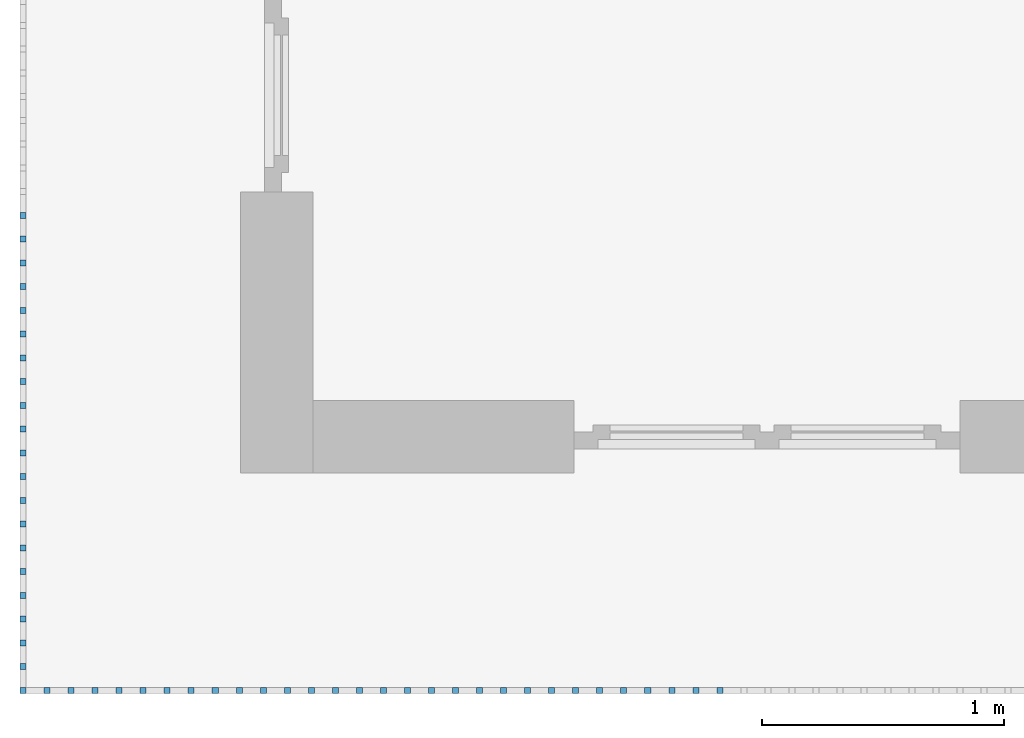
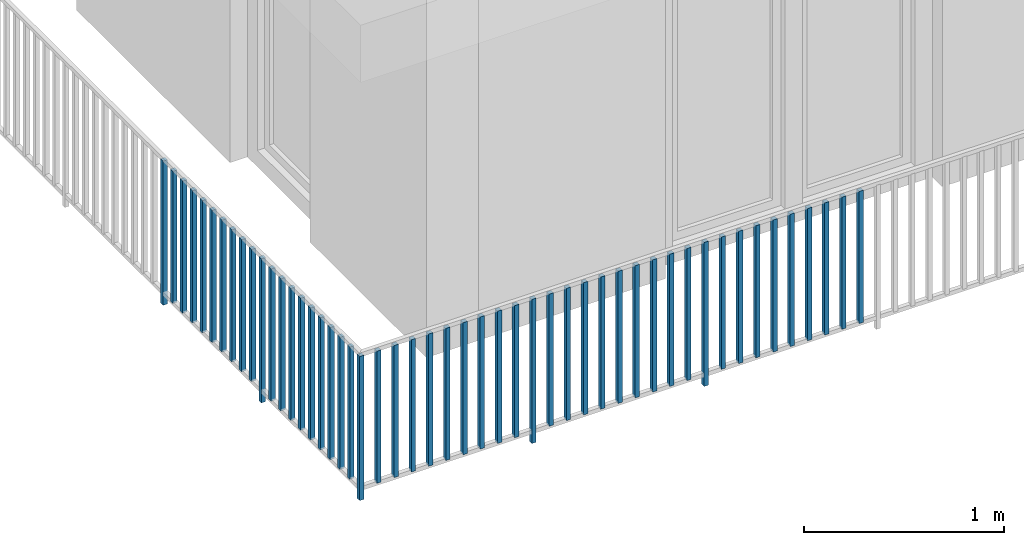
# One storey, part 25 of 48: 50 building element parts, 1 element without a shape of its own.
"""IFC4 building model written with IfcOpenShell, lengths in metres."""

from ifc_helpers import new_model, entity, si_unit, converted_unit, derived_unit, direction, frame, origin_with_axes, place, context, subcontext, project, spatial, polygons, material, type_object, element, aggregate, save


model = new_model("IFC4")

# Units and contexts
model_context = context("Model", 3, precision=1e-05, world=origin_with_axes(), true_north=direction((0.0, 1.0)))
body_context = subcontext(model_context, "Body", "Model", "MODEL_VIEW")
ifc_project = project(units=[si_unit("LENGTHUNIT", "METRE"), si_unit("AREAUNIT", "SQUARE_METRE"), si_unit("VOLUMEUNIT", "CUBIC_METRE"), converted_unit("PLANEANGLEUNIT", "DEGREE", entity("IfcPlaneAngleMeasure", 0.0174532925199), si_unit("PLANEANGLEUNIT", "RADIAN"), dimensions=[0, 0, 0, 0, 0, 0, 0]), converted_unit("TIMEUNIT", "Year", entity("IfcTimeMeasure", 31556926.0), si_unit("TIMEUNIT", "SECOND"), dimensions=[0, 0, 1, 0, 0, 0, 0]), si_unit("MASSUNIT", "GRAM", prefix="KILO"), si_unit("THERMODYNAMICTEMPERATUREUNIT", "DEGREE_CELSIUS"), si_unit("LUMINOUSINTENSITYUNIT", "LUMEN"), si_unit("ENERGYUNIT", "JOULE", prefix="MEGA"), derived_unit("THERMALCONDUCTANCEUNIT", [(si_unit("POWERUNIT", "WATT"), 1), (si_unit("LENGTHUNIT", "METRE"), -1), (si_unit("THERMODYNAMICTEMPERATUREUNIT", "KELVIN"), -1)]), derived_unit("SPECIFICHEATCAPACITYUNIT", [(si_unit("ENERGYUNIT", "JOULE"), 1), (si_unit("MASSUNIT", "GRAM", prefix="KILO"), -1), (si_unit("THERMODYNAMICTEMPERATUREUNIT", "KELVIN"), -1)]), derived_unit("MASSDENSITYUNIT", [(si_unit("MASSUNIT", "GRAM", prefix="KILO"), 1), (si_unit("VOLUMEUNIT", "CUBIC_METRE"), -1)])], contexts=[model_context])

# Site, building, storey
site_placement = place(None, origin_with_axes())
site = spatial("IfcSite", under=ifc_project, at=site_placement, CompositionType="ELEMENT")
building_placement = place(site_placement, origin_with_axes())
building = spatial("IfcBuilding", under=site, at=building_placement, CompositionType="ELEMENT")
storey_placement = place(building_placement, frame((0.0, 0.0, 3.4), z_axis=(0.0, 0.0, 1.0), x_axis=(1.0, 0.0, 0.0)))
storey = spatial("IfcBuildingStorey", under=building, at=storey_placement, Name="1. Geschoss", CompositionType="ELEMENT", Elevation=3.4)

# Railing, building element parts
railing_type = type_object("IfcRailingType", PredefinedType="NOTDEFINED")
railing_placement = place(storey_placement, frame((10.2378006196, 9.82118776896, 0.0), z_axis=(0.0, 0.0, 1.0), x_axis=(1.0, 0.0, 0.0)))
railing = element("IfcRailing", 1, at=railing_placement, inside=storey, type_object=railing_type, PredefinedType="NOTDEFINED")
ifc_material = material()
building_element_part_1_placement = place(railing_placement, origin_with_axes())
building_element_part_1 = element("IfcBuildingElementPart", 2, at=building_element_part_1_placement, material=ifc_material, PredefinedType="NOTDEFINED", context=body_context, shape_type="Tessellation", body=[
    polygons([(-22.8925, -20.6625, 0.0), (-22.8675, -20.6625, 0.0), (-22.8675, -20.6625, 0.88), (-22.8925, -20.6625, 0.88), (-22.8925, -20.6375, 0.0), (-22.8675, -20.6375, 0.0), (-22.8675, -20.6375, 0.88), (-22.8925, -20.6375, 0.88)], [[[1, 2, 3, 4]], [[1, 5, 6, 2]], [[2, 6, 7, 3]], [[4, 3, 7, 8]], [[5, 1, 4, 8]], [[6, 5, 8, 7]]], closed=True),
])
building_element_part_2_placement = place(railing_placement, origin_with_axes())
building_element_part_2 = element("IfcBuildingElementPart", 3, at=building_element_part_2_placement, material=ifc_material, PredefinedType="NOTDEFINED", context=body_context, shape_type="Tessellation", body=[
    polygons([(-22.8925, -18.6958333333, 0.0), (-22.8675, -18.6958333333, 0.0), (-22.8675, -18.6958333333, 0.88), (-22.8925, -18.6958333333, 0.88), (-22.8925, -18.6708333333, 0.0), (-22.8675, -18.6708333333, 0.0), (-22.8675, -18.6708333333, 0.88), (-22.8925, -18.6708333333, 0.88)], [[[1, 2, 3, 4]], [[1, 5, 6, 2]], [[2, 6, 7, 3]], [[4, 3, 7, 8]], [[5, 1, 4, 8]], [[6, 5, 8, 7]]], closed=True),
])
building_element_part_3_placement = place(railing_placement, origin_with_axes())
building_element_part_3 = element("IfcBuildingElementPart", 4, at=building_element_part_3_placement, material=ifc_material, PredefinedType="NOTDEFINED", context=body_context, shape_type="Tessellation", body=[
    polygons([(-22.8925, -18.7941666667, 0.07), (-22.8675, -18.7941666667, 0.07), (-22.8675, -18.7941666667, 0.8775), (-22.8925, -18.7941666667, 0.8775), (-22.8925, -18.7691666667, 0.07), (-22.8675, -18.7691666667, 0.07), (-22.8675, -18.7691666667, 0.8775), (-22.8925, -18.7691666667, 0.8775)], [[[1, 2, 3, 4]], [[1, 5, 6, 2]], [[2, 6, 7, 3]], [[4, 3, 7, 8]], [[5, 1, 4, 8]], [[6, 5, 8, 7]]], closed=True),
])
building_element_part_4_placement = place(railing_placement, origin_with_axes())
building_element_part_4 = element("IfcBuildingElementPart", 5, at=building_element_part_4_placement, material=ifc_material, PredefinedType="NOTDEFINED", context=body_context, shape_type="Tessellation", body=[
    polygons([(-22.8925, -18.8925, 0.07), (-22.8675, -18.8925, 0.07), (-22.8675, -18.8925, 0.8775), (-22.8925, -18.8925, 0.8775), (-22.8925, -18.8675, 0.07), (-22.8675, -18.8675, 0.07), (-22.8675, -18.8675, 0.8775), (-22.8925, -18.8675, 0.8775)], [[[1, 2, 3, 4]], [[1, 5, 6, 2]], [[2, 6, 7, 3]], [[4, 3, 7, 8]], [[5, 1, 4, 8]], [[6, 5, 8, 7]]], closed=True),
])
building_element_part_5_placement = place(railing_placement, origin_with_axes())
building_element_part_5 = element("IfcBuildingElementPart", 6, at=building_element_part_5_placement, material=ifc_material, PredefinedType="NOTDEFINED", context=body_context, shape_type="Tessellation", body=[
    polygons([(-22.8925, -18.9908333333, 0.07), (-22.8675, -18.9908333333, 0.07), (-22.8675, -18.9908333333, 0.8775), (-22.8925, -18.9908333333, 0.8775), (-22.8925, -18.9658333333, 0.07), (-22.8675, -18.9658333333, 0.07), (-22.8675, -18.9658333333, 0.8775), (-22.8925, -18.9658333333, 0.8775)], [[[1, 2, 3, 4]], [[1, 5, 6, 2]], [[2, 6, 7, 3]], [[4, 3, 7, 8]], [[5, 1, 4, 8]], [[6, 5, 8, 7]]], closed=True),
])
building_element_part_6_placement = place(railing_placement, origin_with_axes())
building_element_part_6 = element("IfcBuildingElementPart", 7, at=building_element_part_6_placement, material=ifc_material, PredefinedType="NOTDEFINED", context=body_context, shape_type="Tessellation", body=[
    polygons([(-22.8925, -19.0891666667, 0.07), (-22.8675, -19.0891666667, 0.07), (-22.8675, -19.0891666667, 0.8775), (-22.8925, -19.0891666667, 0.8775), (-22.8925, -19.0641666667, 0.07), (-22.8675, -19.0641666667, 0.07), (-22.8675, -19.0641666667, 0.8775), (-22.8925, -19.0641666667, 0.8775)], [[[1, 2, 3, 4]], [[1, 5, 6, 2]], [[2, 6, 7, 3]], [[4, 3, 7, 8]], [[5, 1, 4, 8]], [[6, 5, 8, 7]]], closed=True),
])
building_element_part_7_placement = place(railing_placement, origin_with_axes())
building_element_part_7 = element("IfcBuildingElementPart", 8, at=building_element_part_7_placement, material=ifc_material, PredefinedType="NOTDEFINED", context=body_context, shape_type="Tessellation", body=[
    polygons([(-22.8925, -19.1875, 0.07), (-22.8675, -19.1875, 0.07), (-22.8675, -19.1875, 0.8775), (-22.8925, -19.1875, 0.8775), (-22.8925, -19.1625, 0.07), (-22.8675, -19.1625, 0.07), (-22.8675, -19.1625, 0.8775), (-22.8925, -19.1625, 0.8775)], [[[1, 2, 3, 4]], [[1, 5, 6, 2]], [[2, 6, 7, 3]], [[4, 3, 7, 8]], [[5, 1, 4, 8]], [[6, 5, 8, 7]]], closed=True),
])
building_element_part_8_placement = place(railing_placement, origin_with_axes())
building_element_part_8 = element("IfcBuildingElementPart", 9, at=building_element_part_8_placement, material=ifc_material, PredefinedType="NOTDEFINED", context=body_context, shape_type="Tessellation", body=[
    polygons([(-22.8925, -19.2858333333, 0.07), (-22.8675, -19.2858333333, 0.07), (-22.8675, -19.2858333333, 0.8775), (-22.8925, -19.2858333333, 0.8775), (-22.8925, -19.2608333333, 0.07), (-22.8675, -19.2608333333, 0.07), (-22.8675, -19.2608333333, 0.8775), (-22.8925, -19.2608333333, 0.8775)], [[[1, 2, 3, 4]], [[1, 5, 6, 2]], [[2, 6, 7, 3]], [[4, 3, 7, 8]], [[5, 1, 4, 8]], [[6, 5, 8, 7]]], closed=True),
])
building_element_part_9_placement = place(railing_placement, origin_with_axes())
building_element_part_9 = element("IfcBuildingElementPart", 10, at=building_element_part_9_placement, material=ifc_material, PredefinedType="NOTDEFINED", context=body_context, shape_type="Tessellation", body=[
    polygons([(-22.8925, -19.3841666667, 0.07), (-22.8675, -19.3841666667, 0.07), (-22.8675, -19.3841666667, 0.8775), (-22.8925, -19.3841666667, 0.8775), (-22.8925, -19.3591666667, 0.07), (-22.8675, -19.3591666667, 0.07), (-22.8675, -19.3591666667, 0.8775), (-22.8925, -19.3591666667, 0.8775)], [[[1, 2, 3, 4]], [[1, 5, 6, 2]], [[2, 6, 7, 3]], [[4, 3, 7, 8]], [[5, 1, 4, 8]], [[6, 5, 8, 7]]], closed=True),
])
building_element_part_10_placement = place(railing_placement, origin_with_axes())
building_element_part_10 = element("IfcBuildingElementPart", 11, at=building_element_part_10_placement, material=ifc_material, PredefinedType="NOTDEFINED", context=body_context, shape_type="Tessellation", body=[
    polygons([(-22.8925, -19.4825, 0.07), (-22.8675, -19.4825, 0.07), (-22.8675, -19.4825, 0.8775), (-22.8925, -19.4825, 0.8775), (-22.8925, -19.4575, 0.07), (-22.8675, -19.4575, 0.07), (-22.8675, -19.4575, 0.8775), (-22.8925, -19.4575, 0.8775)], [[[1, 2, 3, 4]], [[1, 5, 6, 2]], [[2, 6, 7, 3]], [[4, 3, 7, 8]], [[5, 1, 4, 8]], [[6, 5, 8, 7]]], closed=True),
])
building_element_part_11_placement = place(railing_placement, origin_with_axes())
building_element_part_11 = element("IfcBuildingElementPart", 12, at=building_element_part_11_placement, material=ifc_material, PredefinedType="NOTDEFINED", context=body_context, shape_type="Tessellation", body=[
    polygons([(-22.8925, -19.5808333333, 0.07), (-22.8675, -19.5808333333, 0.07), (-22.8675, -19.5808333333, 0.8775), (-22.8925, -19.5808333333, 0.8775), (-22.8925, -19.5558333333, 0.07), (-22.8675, -19.5558333333, 0.07), (-22.8675, -19.5558333333, 0.8775), (-22.8925, -19.5558333333, 0.8775)], [[[1, 2, 3, 4]], [[1, 5, 6, 2]], [[2, 6, 7, 3]], [[4, 3, 7, 8]], [[5, 1, 4, 8]], [[6, 5, 8, 7]]], closed=True),
])
building_element_part_12_placement = place(railing_placement, origin_with_axes())
building_element_part_12 = element("IfcBuildingElementPart", 13, at=building_element_part_12_placement, material=ifc_material, PredefinedType="NOTDEFINED", context=body_context, shape_type="Tessellation", body=[
    polygons([(-22.8925, -19.6791666667, 0.0), (-22.8675, -19.6791666667, 0.0), (-22.8675, -19.6791666667, 0.88), (-22.8925, -19.6791666667, 0.88), (-22.8925, -19.6541666667, 0.0), (-22.8675, -19.6541666667, 0.0), (-22.8675, -19.6541666667, 0.88), (-22.8925, -19.6541666667, 0.88)], [[[1, 2, 3, 4]], [[1, 5, 6, 2]], [[2, 6, 7, 3]], [[4, 3, 7, 8]], [[5, 1, 4, 8]], [[6, 5, 8, 7]]], closed=True),
])
building_element_part_13_placement = place(railing_placement, origin_with_axes())
building_element_part_13 = element("IfcBuildingElementPart", 14, at=building_element_part_13_placement, material=ifc_material, PredefinedType="NOTDEFINED", context=body_context, shape_type="Tessellation", body=[
    polygons([(-22.8925, -19.7775, 0.07), (-22.8675, -19.7775, 0.07), (-22.8675, -19.7775, 0.8775), (-22.8925, -19.7775, 0.8775), (-22.8925, -19.7525, 0.07), (-22.8675, -19.7525, 0.07), (-22.8675, -19.7525, 0.8775), (-22.8925, -19.7525, 0.8775)], [[[1, 2, 3, 4]], [[1, 5, 6, 2]], [[2, 6, 7, 3]], [[4, 3, 7, 8]], [[5, 1, 4, 8]], [[6, 5, 8, 7]]], closed=True),
])
building_element_part_14_placement = place(railing_placement, origin_with_axes())
building_element_part_14 = element("IfcBuildingElementPart", 15, at=building_element_part_14_placement, material=ifc_material, PredefinedType="NOTDEFINED", context=body_context, shape_type="Tessellation", body=[
    polygons([(-22.8925, -19.8758333333, 0.07), (-22.8675, -19.8758333333, 0.07), (-22.8675, -19.8758333333, 0.8775), (-22.8925, -19.8758333333, 0.8775), (-22.8925, -19.8508333333, 0.07), (-22.8675, -19.8508333333, 0.07), (-22.8675, -19.8508333333, 0.8775), (-22.8925, -19.8508333333, 0.8775)], [[[1, 2, 3, 4]], [[1, 5, 6, 2]], [[2, 6, 7, 3]], [[4, 3, 7, 8]], [[5, 1, 4, 8]], [[6, 5, 8, 7]]], closed=True),
])
building_element_part_15_placement = place(railing_placement, origin_with_axes())
building_element_part_15 = element("IfcBuildingElementPart", 16, at=building_element_part_15_placement, material=ifc_material, PredefinedType="NOTDEFINED", context=body_context, shape_type="Tessellation", body=[
    polygons([(-22.8925, -19.9741666667, 0.07), (-22.8675, -19.9741666667, 0.07), (-22.8675, -19.9741666667, 0.8775), (-22.8925, -19.9741666667, 0.8775), (-22.8925, -19.9491666667, 0.07), (-22.8675, -19.9491666667, 0.07), (-22.8675, -19.9491666667, 0.8775), (-22.8925, -19.9491666667, 0.8775)], [[[1, 2, 3, 4]], [[1, 5, 6, 2]], [[2, 6, 7, 3]], [[4, 3, 7, 8]], [[5, 1, 4, 8]], [[6, 5, 8, 7]]], closed=True),
])
building_element_part_16_placement = place(railing_placement, origin_with_axes())
building_element_part_16 = element("IfcBuildingElementPart", 17, at=building_element_part_16_placement, material=ifc_material, PredefinedType="NOTDEFINED", context=body_context, shape_type="Tessellation", body=[
    polygons([(-22.8925, -20.0725, 0.07), (-22.8675, -20.0725, 0.07), (-22.8675, -20.0725, 0.8775), (-22.8925, -20.0725, 0.8775), (-22.8925, -20.0475, 0.07), (-22.8675, -20.0475, 0.07), (-22.8675, -20.0475, 0.8775), (-22.8925, -20.0475, 0.8775)], [[[1, 2, 3, 4]], [[1, 5, 6, 2]], [[2, 6, 7, 3]], [[4, 3, 7, 8]], [[5, 1, 4, 8]], [[6, 5, 8, 7]]], closed=True),
])
building_element_part_17_placement = place(railing_placement, origin_with_axes())
building_element_part_17 = element("IfcBuildingElementPart", 18, at=building_element_part_17_placement, material=ifc_material, PredefinedType="NOTDEFINED", context=body_context, shape_type="Tessellation", body=[
    polygons([(-22.8925, -20.1708333333, 0.07), (-22.8675, -20.1708333333, 0.07), (-22.8675, -20.1708333333, 0.8775), (-22.8925, -20.1708333333, 0.8775), (-22.8925, -20.1458333333, 0.07), (-22.8675, -20.1458333333, 0.07), (-22.8675, -20.1458333333, 0.8775), (-22.8925, -20.1458333333, 0.8775)], [[[1, 2, 3, 4]], [[1, 5, 6, 2]], [[2, 6, 7, 3]], [[4, 3, 7, 8]], [[5, 1, 4, 8]], [[6, 5, 8, 7]]], closed=True),
])
building_element_part_18_placement = place(railing_placement, origin_with_axes())
building_element_part_18 = element("IfcBuildingElementPart", 19, at=building_element_part_18_placement, material=ifc_material, PredefinedType="NOTDEFINED", context=body_context, shape_type="Tessellation", body=[
    polygons([(-22.8925, -20.2691666667, 0.07), (-22.8675, -20.2691666667, 0.07), (-22.8675, -20.2691666667, 0.8775), (-22.8925, -20.2691666667, 0.8775), (-22.8925, -20.2441666667, 0.07), (-22.8675, -20.2441666667, 0.07), (-22.8675, -20.2441666667, 0.8775), (-22.8925, -20.2441666667, 0.8775)], [[[1, 2, 3, 4]], [[1, 5, 6, 2]], [[2, 6, 7, 3]], [[4, 3, 7, 8]], [[5, 1, 4, 8]], [[6, 5, 8, 7]]], closed=True),
])
building_element_part_19_placement = place(railing_placement, origin_with_axes())
building_element_part_19 = element("IfcBuildingElementPart", 20, at=building_element_part_19_placement, material=ifc_material, PredefinedType="NOTDEFINED", context=body_context, shape_type="Tessellation", body=[
    polygons([(-22.8925, -20.3675, 0.07), (-22.8675, -20.3675, 0.07), (-22.8675, -20.3675, 0.8775), (-22.8925, -20.3675, 0.8775), (-22.8925, -20.3425, 0.07), (-22.8675, -20.3425, 0.07), (-22.8675, -20.3425, 0.8775), (-22.8925, -20.3425, 0.8775)], [[[1, 2, 3, 4]], [[1, 5, 6, 2]], [[2, 6, 7, 3]], [[4, 3, 7, 8]], [[5, 1, 4, 8]], [[6, 5, 8, 7]]], closed=True),
])
building_element_part_20_placement = place(railing_placement, origin_with_axes())
building_element_part_20 = element("IfcBuildingElementPart", 21, at=building_element_part_20_placement, material=ifc_material, PredefinedType="NOTDEFINED", context=body_context, shape_type="Tessellation", body=[
    polygons([(-22.8925, -20.4658333333, 0.07), (-22.8675, -20.4658333333, 0.07), (-22.8675, -20.4658333333, 0.8775), (-22.8925, -20.4658333333, 0.8775), (-22.8925, -20.4408333333, 0.07), (-22.8675, -20.4408333333, 0.07), (-22.8675, -20.4408333333, 0.8775), (-22.8925, -20.4408333333, 0.8775)], [[[1, 2, 3, 4]], [[1, 5, 6, 2]], [[2, 6, 7, 3]], [[4, 3, 7, 8]], [[5, 1, 4, 8]], [[6, 5, 8, 7]]], closed=True),
])
building_element_part_21_placement = place(railing_placement, origin_with_axes())
building_element_part_21 = element("IfcBuildingElementPart", 22, at=building_element_part_21_placement, material=ifc_material, PredefinedType="NOTDEFINED", context=body_context, shape_type="Tessellation", body=[
    polygons([(-22.8925, -20.5641666667, 0.07), (-22.8675, -20.5641666667, 0.07), (-22.8675, -20.5641666667, 0.8775), (-22.8925, -20.5641666667, 0.8775), (-22.8925, -20.5391666667, 0.07), (-22.8675, -20.5391666667, 0.07), (-22.8675, -20.5391666667, 0.8775), (-22.8925, -20.5391666667, 0.8775)], [[[1, 2, 3, 4]], [[1, 5, 6, 2]], [[2, 6, 7, 3]], [[4, 3, 7, 8]], [[5, 1, 4, 8]], [[6, 5, 8, 7]]], closed=True),
])
building_element_part_22_placement = place(railing_placement, origin_with_axes())
building_element_part_22 = element("IfcBuildingElementPart", 23, at=building_element_part_22_placement, material=ifc_material, PredefinedType="NOTDEFINED", context=body_context, shape_type="Tessellation", body=[
    polygons([(-22.7680217391, -20.6625, 0.07), (-22.7680217391, -20.6375, 0.07), (-22.7680217391, -20.6375, 0.8775), (-22.7680217391, -20.6625, 0.8775), (-22.7930217391, -20.6625, 0.07), (-22.7930217391, -20.6375, 0.07), (-22.7930217391, -20.6375, 0.8775), (-22.7930217391, -20.6625, 0.8775)], [[[1, 2, 3, 4]], [[1, 5, 6, 2]], [[2, 6, 7, 3]], [[4, 3, 7, 8]], [[5, 1, 4, 8]], [[6, 5, 8, 7]]], closed=True),
])
building_element_part_23_placement = place(railing_placement, origin_with_axes())
building_element_part_23 = element("IfcBuildingElementPart", 24, at=building_element_part_23_placement, material=ifc_material, PredefinedType="NOTDEFINED", context=body_context, shape_type="Tessellation", body=[
    polygons([(-22.6685434783, -20.6625, 0.07), (-22.6685434783, -20.6375, 0.07), (-22.6685434783, -20.6375, 0.8775), (-22.6685434783, -20.6625, 0.8775), (-22.6935434783, -20.6625, 0.07), (-22.6935434783, -20.6375, 0.07), (-22.6935434783, -20.6375, 0.8775), (-22.6935434783, -20.6625, 0.8775)], [[[1, 2, 3, 4]], [[1, 5, 6, 2]], [[2, 6, 7, 3]], [[4, 3, 7, 8]], [[5, 1, 4, 8]], [[6, 5, 8, 7]]], closed=True),
])
building_element_part_24_placement = place(railing_placement, origin_with_axes())
building_element_part_24 = element("IfcBuildingElementPart", 25, at=building_element_part_24_placement, material=ifc_material, PredefinedType="NOTDEFINED", context=body_context, shape_type="Tessellation", body=[
    polygons([(-22.5690652174, -20.6625, 0.07), (-22.5690652174, -20.6375, 0.07), (-22.5690652174, -20.6375, 0.8775), (-22.5690652174, -20.6625, 0.8775), (-22.5940652174, -20.6625, 0.07), (-22.5940652174, -20.6375, 0.07), (-22.5940652174, -20.6375, 0.8775), (-22.5940652174, -20.6625, 0.8775)], [[[1, 2, 3, 4]], [[1, 5, 6, 2]], [[2, 6, 7, 3]], [[4, 3, 7, 8]], [[5, 1, 4, 8]], [[6, 5, 8, 7]]], closed=True),
])
building_element_part_25_placement = place(railing_placement, origin_with_axes())
building_element_part_25 = element("IfcBuildingElementPart", 26, at=building_element_part_25_placement, material=ifc_material, PredefinedType="NOTDEFINED", context=body_context, shape_type="Tessellation", body=[
    polygons([(-22.4695869565, -20.6625, 0.07), (-22.4695869565, -20.6375, 0.07), (-22.4695869565, -20.6375, 0.8775), (-22.4695869565, -20.6625, 0.8775), (-22.4945869565, -20.6625, 0.07), (-22.4945869565, -20.6375, 0.07), (-22.4945869565, -20.6375, 0.8775), (-22.4945869565, -20.6625, 0.8775)], [[[1, 2, 3, 4]], [[1, 5, 6, 2]], [[2, 6, 7, 3]], [[4, 3, 7, 8]], [[5, 1, 4, 8]], [[6, 5, 8, 7]]], closed=True),
])
building_element_part_26_placement = place(railing_placement, origin_with_axes())
building_element_part_26 = element("IfcBuildingElementPart", 27, at=building_element_part_26_placement, material=ifc_material, PredefinedType="NOTDEFINED", context=body_context, shape_type="Tessellation", body=[
    polygons([(-22.3701086957, -20.6625, 0.07), (-22.3701086957, -20.6375, 0.07), (-22.3701086957, -20.6375, 0.8775), (-22.3701086957, -20.6625, 0.8775), (-22.3951086957, -20.6625, 0.07), (-22.3951086957, -20.6375, 0.07), (-22.3951086957, -20.6375, 0.8775), (-22.3951086957, -20.6625, 0.8775)], [[[1, 2, 3, 4]], [[1, 5, 6, 2]], [[2, 6, 7, 3]], [[4, 3, 7, 8]], [[5, 1, 4, 8]], [[6, 5, 8, 7]]], closed=True),
])
building_element_part_27_placement = place(railing_placement, origin_with_axes())
building_element_part_27 = element("IfcBuildingElementPart", 28, at=building_element_part_27_placement, material=ifc_material, PredefinedType="NOTDEFINED", context=body_context, shape_type="Tessellation", body=[
    polygons([(-22.2706304348, -20.6625, 0.07), (-22.2706304348, -20.6375, 0.07), (-22.2706304348, -20.6375, 0.8775), (-22.2706304348, -20.6625, 0.8775), (-22.2956304348, -20.6625, 0.07), (-22.2956304348, -20.6375, 0.07), (-22.2956304348, -20.6375, 0.8775), (-22.2956304348, -20.6625, 0.8775)], [[[1, 2, 3, 4]], [[1, 5, 6, 2]], [[2, 6, 7, 3]], [[4, 3, 7, 8]], [[5, 1, 4, 8]], [[6, 5, 8, 7]]], closed=True),
])
building_element_part_28_placement = place(railing_placement, origin_with_axes())
building_element_part_28 = element("IfcBuildingElementPart", 29, at=building_element_part_28_placement, material=ifc_material, PredefinedType="NOTDEFINED", context=body_context, shape_type="Tessellation", body=[
    polygons([(-22.1711521739, -20.6625, 0.07), (-22.1711521739, -20.6375, 0.07), (-22.1711521739, -20.6375, 0.8775), (-22.1711521739, -20.6625, 0.8775), (-22.1961521739, -20.6625, 0.07), (-22.1961521739, -20.6375, 0.07), (-22.1961521739, -20.6375, 0.8775), (-22.1961521739, -20.6625, 0.8775)], [[[1, 2, 3, 4]], [[1, 5, 6, 2]], [[2, 6, 7, 3]], [[4, 3, 7, 8]], [[5, 1, 4, 8]], [[6, 5, 8, 7]]], closed=True),
])
building_element_part_29_placement = place(railing_placement, origin_with_axes())
building_element_part_29 = element("IfcBuildingElementPart", 30, at=building_element_part_29_placement, material=ifc_material, PredefinedType="NOTDEFINED", context=body_context, shape_type="Tessellation", body=[
    polygons([(-22.071673913, -20.6625, 0.07), (-22.071673913, -20.6375, 0.07), (-22.071673913, -20.6375, 0.8775), (-22.071673913, -20.6625, 0.8775), (-22.096673913, -20.6625, 0.07), (-22.096673913, -20.6375, 0.07), (-22.096673913, -20.6375, 0.8775), (-22.096673913, -20.6625, 0.8775)], [[[1, 2, 3, 4]], [[1, 5, 6, 2]], [[2, 6, 7, 3]], [[4, 3, 7, 8]], [[5, 1, 4, 8]], [[6, 5, 8, 7]]], closed=True),
])
building_element_part_30_placement = place(railing_placement, origin_with_axes())
building_element_part_30 = element("IfcBuildingElementPart", 31, at=building_element_part_30_placement, material=ifc_material, PredefinedType="NOTDEFINED", context=body_context, shape_type="Tessellation", body=[
    polygons([(-21.9721956522, -20.6625, 0.07), (-21.9721956522, -20.6375, 0.07), (-21.9721956522, -20.6375, 0.8775), (-21.9721956522, -20.6625, 0.8775), (-21.9971956522, -20.6625, 0.07), (-21.9971956522, -20.6375, 0.07), (-21.9971956522, -20.6375, 0.8775), (-21.9971956522, -20.6625, 0.8775)], [[[1, 2, 3, 4]], [[1, 5, 6, 2]], [[2, 6, 7, 3]], [[4, 3, 7, 8]], [[5, 1, 4, 8]], [[6, 5, 8, 7]]], closed=True),
])
building_element_part_31_placement = place(railing_placement, origin_with_axes())
building_element_part_31 = element("IfcBuildingElementPart", 32, at=building_element_part_31_placement, material=ifc_material, PredefinedType="NOTDEFINED", context=body_context, shape_type="Tessellation", body=[
    polygons([(-21.8727173913, -20.6625, 0.0), (-21.8727173913, -20.6375, 0.0), (-21.8727173913, -20.6375, 0.88), (-21.8727173913, -20.6625, 0.88), (-21.8977173913, -20.6625, 0.0), (-21.8977173913, -20.6375, 0.0), (-21.8977173913, -20.6375, 0.88), (-21.8977173913, -20.6625, 0.88)], [[[1, 2, 3, 4]], [[1, 5, 6, 2]], [[2, 6, 7, 3]], [[4, 3, 7, 8]], [[5, 1, 4, 8]], [[6, 5, 8, 7]]], closed=True),
])
building_element_part_32_placement = place(railing_placement, origin_with_axes())
building_element_part_32 = element("IfcBuildingElementPart", 33, at=building_element_part_32_placement, material=ifc_material, PredefinedType="NOTDEFINED", context=body_context, shape_type="Tessellation", body=[
    polygons([(-21.7732391304, -20.6625, 0.07), (-21.7732391304, -20.6375, 0.07), (-21.7732391304, -20.6375, 0.8775), (-21.7732391304, -20.6625, 0.8775), (-21.7982391304, -20.6625, 0.07), (-21.7982391304, -20.6375, 0.07), (-21.7982391304, -20.6375, 0.8775), (-21.7982391304, -20.6625, 0.8775)], [[[1, 2, 3, 4]], [[1, 5, 6, 2]], [[2, 6, 7, 3]], [[4, 3, 7, 8]], [[5, 1, 4, 8]], [[6, 5, 8, 7]]], closed=True),
])
building_element_part_33_placement = place(railing_placement, origin_with_axes())
building_element_part_33 = element("IfcBuildingElementPart", 34, at=building_element_part_33_placement, material=ifc_material, PredefinedType="NOTDEFINED", context=body_context, shape_type="Tessellation", body=[
    polygons([(-21.6737608696, -20.6625, 0.07), (-21.6737608696, -20.6375, 0.07), (-21.6737608696, -20.6375, 0.8775), (-21.6737608696, -20.6625, 0.8775), (-21.6987608696, -20.6625, 0.07), (-21.6987608696, -20.6375, 0.07), (-21.6987608696, -20.6375, 0.8775), (-21.6987608696, -20.6625, 0.8775)], [[[1, 2, 3, 4]], [[1, 5, 6, 2]], [[2, 6, 7, 3]], [[4, 3, 7, 8]], [[5, 1, 4, 8]], [[6, 5, 8, 7]]], closed=True),
])
building_element_part_34_placement = place(railing_placement, origin_with_axes())
building_element_part_34 = element("IfcBuildingElementPart", 35, at=building_element_part_34_placement, material=ifc_material, PredefinedType="NOTDEFINED", context=body_context, shape_type="Tessellation", body=[
    polygons([(-21.5742826087, -20.6625, 0.07), (-21.5742826087, -20.6375, 0.07), (-21.5742826087, -20.6375, 0.8775), (-21.5742826087, -20.6625, 0.8775), (-21.5992826087, -20.6625, 0.07), (-21.5992826087, -20.6375, 0.07), (-21.5992826087, -20.6375, 0.8775), (-21.5992826087, -20.6625, 0.8775)], [[[1, 2, 3, 4]], [[1, 5, 6, 2]], [[2, 6, 7, 3]], [[4, 3, 7, 8]], [[5, 1, 4, 8]], [[6, 5, 8, 7]]], closed=True),
])
building_element_part_35_placement = place(railing_placement, origin_with_axes())
building_element_part_35 = element("IfcBuildingElementPart", 36, at=building_element_part_35_placement, material=ifc_material, PredefinedType="NOTDEFINED", context=body_context, shape_type="Tessellation", body=[
    polygons([(-21.4748043478, -20.6625, 0.07), (-21.4748043478, -20.6375, 0.07), (-21.4748043478, -20.6375, 0.8775), (-21.4748043478, -20.6625, 0.8775), (-21.4998043478, -20.6625, 0.07), (-21.4998043478, -20.6375, 0.07), (-21.4998043478, -20.6375, 0.8775), (-21.4998043478, -20.6625, 0.8775)], [[[1, 2, 3, 4]], [[1, 5, 6, 2]], [[2, 6, 7, 3]], [[4, 3, 7, 8]], [[5, 1, 4, 8]], [[6, 5, 8, 7]]], closed=True),
])
building_element_part_36_placement = place(railing_placement, origin_with_axes())
building_element_part_36 = element("IfcBuildingElementPart", 37, at=building_element_part_36_placement, material=ifc_material, PredefinedType="NOTDEFINED", context=body_context, shape_type="Tessellation", body=[
    polygons([(-21.375326087, -20.6625, 0.07), (-21.375326087, -20.6375, 0.07), (-21.375326087, -20.6375, 0.8775), (-21.375326087, -20.6625, 0.8775), (-21.400326087, -20.6625, 0.07), (-21.400326087, -20.6375, 0.07), (-21.400326087, -20.6375, 0.8775), (-21.400326087, -20.6625, 0.8775)], [[[1, 2, 3, 4]], [[1, 5, 6, 2]], [[2, 6, 7, 3]], [[4, 3, 7, 8]], [[5, 1, 4, 8]], [[6, 5, 8, 7]]], closed=True),
])
building_element_part_37_placement = place(railing_placement, origin_with_axes())
building_element_part_37 = element("IfcBuildingElementPart", 38, at=building_element_part_37_placement, material=ifc_material, PredefinedType="NOTDEFINED", context=body_context, shape_type="Tessellation", body=[
    polygons([(-21.2758478261, -20.6625, 0.07), (-21.2758478261, -20.6375, 0.07), (-21.2758478261, -20.6375, 0.8775), (-21.2758478261, -20.6625, 0.8775), (-21.3008478261, -20.6625, 0.07), (-21.3008478261, -20.6375, 0.07), (-21.3008478261, -20.6375, 0.8775), (-21.3008478261, -20.6625, 0.8775)], [[[1, 2, 3, 4]], [[1, 5, 6, 2]], [[2, 6, 7, 3]], [[4, 3, 7, 8]], [[5, 1, 4, 8]], [[6, 5, 8, 7]]], closed=True),
])
building_element_part_38_placement = place(railing_placement, origin_with_axes())
building_element_part_38 = element("IfcBuildingElementPart", 39, at=building_element_part_38_placement, material=ifc_material, PredefinedType="NOTDEFINED", context=body_context, shape_type="Tessellation", body=[
    polygons([(-21.1763695652, -20.6625, 0.07), (-21.1763695652, -20.6375, 0.07), (-21.1763695652, -20.6375, 0.8775), (-21.1763695652, -20.6625, 0.8775), (-21.2013695652, -20.6625, 0.07), (-21.2013695652, -20.6375, 0.07), (-21.2013695652, -20.6375, 0.8775), (-21.2013695652, -20.6625, 0.8775)], [[[1, 2, 3, 4]], [[1, 5, 6, 2]], [[2, 6, 7, 3]], [[4, 3, 7, 8]], [[5, 1, 4, 8]], [[6, 5, 8, 7]]], closed=True),
])
building_element_part_39_placement = place(railing_placement, origin_with_axes())
building_element_part_39 = element("IfcBuildingElementPart", 40, at=building_element_part_39_placement, material=ifc_material, PredefinedType="NOTDEFINED", context=body_context, shape_type="Tessellation", body=[
    polygons([(-21.0768913043, -20.6625, 0.07), (-21.0768913043, -20.6375, 0.07), (-21.0768913043, -20.6375, 0.8775), (-21.0768913043, -20.6625, 0.8775), (-21.1018913043, -20.6625, 0.07), (-21.1018913043, -20.6375, 0.07), (-21.1018913043, -20.6375, 0.8775), (-21.1018913043, -20.6625, 0.8775)], [[[1, 2, 3, 4]], [[1, 5, 6, 2]], [[2, 6, 7, 3]], [[4, 3, 7, 8]], [[5, 1, 4, 8]], [[6, 5, 8, 7]]], closed=True),
])
building_element_part_40_placement = place(railing_placement, origin_with_axes())
building_element_part_40 = element("IfcBuildingElementPart", 41, at=building_element_part_40_placement, material=ifc_material, PredefinedType="NOTDEFINED", context=body_context, shape_type="Tessellation", body=[
    polygons([(-20.9774130435, -20.6625, 0.07), (-20.9774130435, -20.6375, 0.07), (-20.9774130435, -20.6375, 0.8775), (-20.9774130435, -20.6625, 0.8775), (-21.0024130435, -20.6625, 0.07), (-21.0024130435, -20.6375, 0.07), (-21.0024130435, -20.6375, 0.8775), (-21.0024130435, -20.6625, 0.8775)], [[[1, 2, 3, 4]], [[1, 5, 6, 2]], [[2, 6, 7, 3]], [[4, 3, 7, 8]], [[5, 1, 4, 8]], [[6, 5, 8, 7]]], closed=True),
])
building_element_part_41_placement = place(railing_placement, origin_with_axes())
building_element_part_41 = element("IfcBuildingElementPart", 42, at=building_element_part_41_placement, material=ifc_material, PredefinedType="NOTDEFINED", context=body_context, shape_type="Tessellation", body=[
    polygons([(-20.8779347826, -20.6625, 0.0), (-20.8779347826, -20.6375, 0.0), (-20.8779347826, -20.6375, 0.88), (-20.8779347826, -20.6625, 0.88), (-20.9029347826, -20.6625, 0.0), (-20.9029347826, -20.6375, 0.0), (-20.9029347826, -20.6375, 0.88), (-20.9029347826, -20.6625, 0.88)], [[[1, 2, 3, 4]], [[1, 5, 6, 2]], [[2, 6, 7, 3]], [[4, 3, 7, 8]], [[5, 1, 4, 8]], [[6, 5, 8, 7]]], closed=True),
])
building_element_part_42_placement = place(railing_placement, origin_with_axes())
building_element_part_42 = element("IfcBuildingElementPart", 43, at=building_element_part_42_placement, material=ifc_material, PredefinedType="NOTDEFINED", context=body_context, shape_type="Tessellation", body=[
    polygons([(-20.7784565217, -20.6625, 0.07), (-20.7784565217, -20.6375, 0.07), (-20.7784565217, -20.6375, 0.8775), (-20.7784565217, -20.6625, 0.8775), (-20.8034565217, -20.6625, 0.07), (-20.8034565217, -20.6375, 0.07), (-20.8034565217, -20.6375, 0.8775), (-20.8034565217, -20.6625, 0.8775)], [[[1, 2, 3, 4]], [[1, 5, 6, 2]], [[2, 6, 7, 3]], [[4, 3, 7, 8]], [[5, 1, 4, 8]], [[6, 5, 8, 7]]], closed=True),
])
building_element_part_43_placement = place(railing_placement, origin_with_axes())
building_element_part_43 = element("IfcBuildingElementPart", 44, at=building_element_part_43_placement, material=ifc_material, PredefinedType="NOTDEFINED", context=body_context, shape_type="Tessellation", body=[
    polygons([(-20.6789782609, -20.6625, 0.07), (-20.6789782609, -20.6375, 0.07), (-20.6789782609, -20.6375, 0.8775), (-20.6789782609, -20.6625, 0.8775), (-20.7039782609, -20.6625, 0.07), (-20.7039782609, -20.6375, 0.07), (-20.7039782609, -20.6375, 0.8775), (-20.7039782609, -20.6625, 0.8775)], [[[1, 2, 3, 4]], [[1, 5, 6, 2]], [[2, 6, 7, 3]], [[4, 3, 7, 8]], [[5, 1, 4, 8]], [[6, 5, 8, 7]]], closed=True),
])
building_element_part_44_placement = place(railing_placement, origin_with_axes())
building_element_part_44 = element("IfcBuildingElementPart", 45, at=building_element_part_44_placement, material=ifc_material, PredefinedType="NOTDEFINED", context=body_context, shape_type="Tessellation", body=[
    polygons([(-20.5795, -20.6625, 0.07), (-20.5795, -20.6375, 0.07), (-20.5795, -20.6375, 0.8775), (-20.5795, -20.6625, 0.8775), (-20.6045, -20.6625, 0.07), (-20.6045, -20.6375, 0.07), (-20.6045, -20.6375, 0.8775), (-20.6045, -20.6625, 0.8775)], [[[1, 2, 3, 4]], [[1, 5, 6, 2]], [[2, 6, 7, 3]], [[4, 3, 7, 8]], [[5, 1, 4, 8]], [[6, 5, 8, 7]]], closed=True),
])
building_element_part_45_placement = place(railing_placement, origin_with_axes())
building_element_part_45 = element("IfcBuildingElementPart", 46, at=building_element_part_45_placement, material=ifc_material, PredefinedType="NOTDEFINED", context=body_context, shape_type="Tessellation", body=[
    polygons([(-20.4800217391, -20.6625, 0.07), (-20.4800217391, -20.6375, 0.07), (-20.4800217391, -20.6375, 0.8775), (-20.4800217391, -20.6625, 0.8775), (-20.5050217391, -20.6625, 0.07), (-20.5050217391, -20.6375, 0.07), (-20.5050217391, -20.6375, 0.8775), (-20.5050217391, -20.6625, 0.8775)], [[[1, 2, 3, 4]], [[1, 5, 6, 2]], [[2, 6, 7, 3]], [[4, 3, 7, 8]], [[5, 1, 4, 8]], [[6, 5, 8, 7]]], closed=True),
])
building_element_part_46_placement = place(railing_placement, origin_with_axes())
building_element_part_46 = element("IfcBuildingElementPart", 47, at=building_element_part_46_placement, material=ifc_material, PredefinedType="NOTDEFINED", context=body_context, shape_type="Tessellation", body=[
    polygons([(-20.3805434783, -20.6625, 0.07), (-20.3805434783, -20.6375, 0.07), (-20.3805434783, -20.6375, 0.8775), (-20.3805434783, -20.6625, 0.8775), (-20.4055434783, -20.6625, 0.07), (-20.4055434783, -20.6375, 0.07), (-20.4055434783, -20.6375, 0.8775), (-20.4055434783, -20.6625, 0.8775)], [[[1, 2, 3, 4]], [[1, 5, 6, 2]], [[2, 6, 7, 3]], [[4, 3, 7, 8]], [[5, 1, 4, 8]], [[6, 5, 8, 7]]], closed=True),
])
building_element_part_47_placement = place(railing_placement, origin_with_axes())
building_element_part_47 = element("IfcBuildingElementPart", 48, at=building_element_part_47_placement, material=ifc_material, PredefinedType="NOTDEFINED", context=body_context, shape_type="Tessellation", body=[
    polygons([(-20.2810652174, -20.6625, 0.07), (-20.2810652174, -20.6375, 0.07), (-20.2810652174, -20.6375, 0.8775), (-20.2810652174, -20.6625, 0.8775), (-20.3060652174, -20.6625, 0.07), (-20.3060652174, -20.6375, 0.07), (-20.3060652174, -20.6375, 0.8775), (-20.3060652174, -20.6625, 0.8775)], [[[1, 2, 3, 4]], [[1, 5, 6, 2]], [[2, 6, 7, 3]], [[4, 3, 7, 8]], [[5, 1, 4, 8]], [[6, 5, 8, 7]]], closed=True),
])
building_element_part_48_placement = place(railing_placement, origin_with_axes())
building_element_part_48 = element("IfcBuildingElementPart", 49, at=building_element_part_48_placement, material=ifc_material, PredefinedType="NOTDEFINED", context=body_context, shape_type="Tessellation", body=[
    polygons([(-20.1815869565, -20.6625, 0.07), (-20.1815869565, -20.6375, 0.07), (-20.1815869565, -20.6375, 0.8775), (-20.1815869565, -20.6625, 0.8775), (-20.2065869565, -20.6625, 0.07), (-20.2065869565, -20.6375, 0.07), (-20.2065869565, -20.6375, 0.8775), (-20.2065869565, -20.6625, 0.8775)], [[[1, 2, 3, 4]], [[1, 5, 6, 2]], [[2, 6, 7, 3]], [[4, 3, 7, 8]], [[5, 1, 4, 8]], [[6, 5, 8, 7]]], closed=True),
])
building_element_part_49_placement = place(railing_placement, origin_with_axes())
building_element_part_49 = element("IfcBuildingElementPart", 50, at=building_element_part_49_placement, material=ifc_material, PredefinedType="NOTDEFINED", context=body_context, shape_type="Tessellation", body=[
    polygons([(-20.0821086957, -20.6625, 0.07), (-20.0821086957, -20.6375, 0.07), (-20.0821086957, -20.6375, 0.8775), (-20.0821086957, -20.6625, 0.8775), (-20.1071086957, -20.6625, 0.07), (-20.1071086957, -20.6375, 0.07), (-20.1071086957, -20.6375, 0.8775), (-20.1071086957, -20.6625, 0.8775)], [[[1, 2, 3, 4]], [[1, 5, 6, 2]], [[2, 6, 7, 3]], [[4, 3, 7, 8]], [[5, 1, 4, 8]], [[6, 5, 8, 7]]], closed=True),
])
building_element_part_50_placement = place(railing_placement, origin_with_axes())
building_element_part_50 = element("IfcBuildingElementPart", 51, at=building_element_part_50_placement, material=ifc_material, PredefinedType="NOTDEFINED", context=body_context, shape_type="Tessellation", body=[
    polygons([(-19.9826304348, -20.6625, 0.07), (-19.9826304348, -20.6375, 0.07), (-19.9826304348, -20.6375, 0.8775), (-19.9826304348, -20.6625, 0.8775), (-20.0076304348, -20.6625, 0.07), (-20.0076304348, -20.6375, 0.07), (-20.0076304348, -20.6375, 0.8775), (-20.0076304348, -20.6625, 0.8775)], [[[1, 2, 3, 4]], [[1, 5, 6, 2]], [[2, 6, 7, 3]], [[4, 3, 7, 8]], [[5, 1, 4, 8]], [[6, 5, 8, 7]]], closed=True),
])
aggregate(railing, [building_element_part_1, building_element_part_2, building_element_part_3, building_element_part_4, building_element_part_5, building_element_part_6, building_element_part_7, building_element_part_8, building_element_part_9, building_element_part_10, building_element_part_11, building_element_part_12, building_element_part_13, building_element_part_14, building_element_part_15, building_element_part_16, building_element_part_17, building_element_part_18, building_element_part_19, building_element_part_20, building_element_part_21, building_element_part_22, building_element_part_23, building_element_part_24, building_element_part_25, building_element_part_26, building_element_part_27, building_element_part_28, building_element_part_29, building_element_part_30, building_element_part_31, building_element_part_32, building_element_part_33, building_element_part_34, building_element_part_35, building_element_part_36, building_element_part_37, building_element_part_38, building_element_part_39, building_element_part_40, building_element_part_41, building_element_part_42, building_element_part_43, building_element_part_44, building_element_part_45, building_element_part_46, building_element_part_47, building_element_part_48, building_element_part_49, building_element_part_50])

save(model, "model.ifc")
